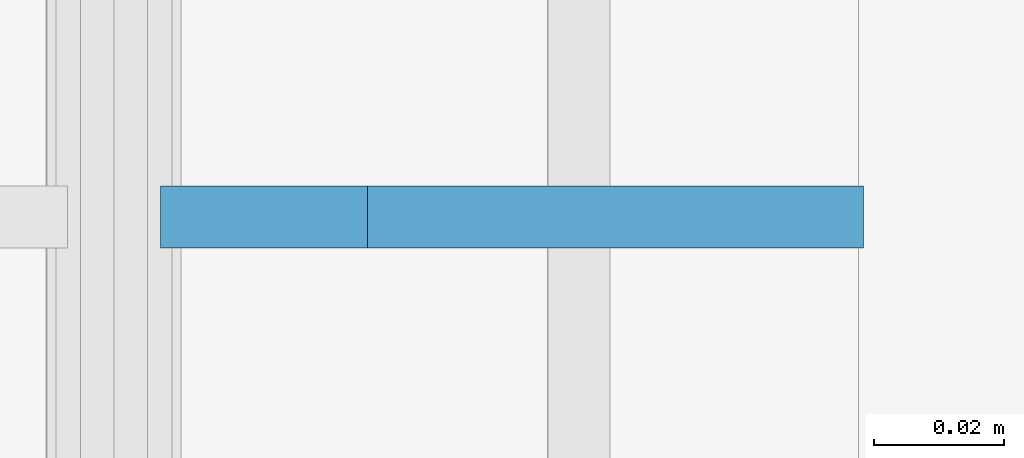
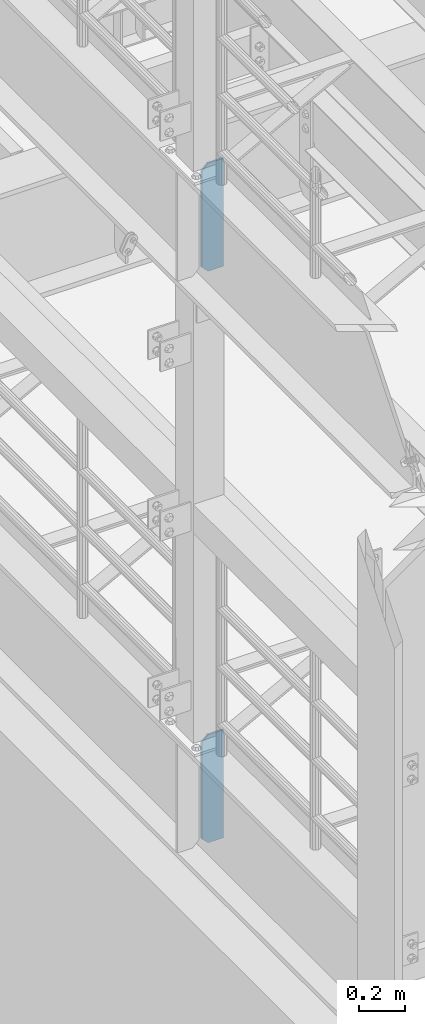
# One storey, part 1483 of 1876: 2 plates, 2 elements without a shape of their own.
"""IFC2X3 building model written with IfcOpenShell, lengths in millimetres."""

from ifc_helpers import new_model, si_unit, frame, origin_with_axes, place, context, subcontext, project, spatial, faceted_brep, material, type_object, element, aggregate, save


model = new_model("IFC2X3")

# Units and contexts
model_context = context("Model", 3, precision=1e-05, world=origin_with_axes())
body_context = subcontext(model_context, "Body", "Model", "MODEL_VIEW")
ifc_project = project(units=[si_unit("LENGTHUNIT", "METRE", prefix="MILLI"), si_unit("AREAUNIT", "SQUARE_METRE"), si_unit("VOLUMEUNIT", "CUBIC_METRE"), si_unit("MASSUNIT", "GRAM", prefix="KILO"), si_unit("TIMEUNIT", "SECOND"), si_unit("PLANEANGLEUNIT", "RADIAN"), si_unit("SOLIDANGLEUNIT", "STERADIAN"), si_unit("THERMODYNAMICTEMPERATUREUNIT", "DEGREE_CELSIUS"), si_unit("LUMINOUSINTENSITYUNIT", "LUMEN")], contexts=[model_context])

# Site, building, storey
site_placement = place(None, origin_with_axes())
site = spatial("IfcSite", under=ifc_project, at=site_placement, CompositionType="ELEMENT")
building_placement = place(site_placement, origin_with_axes())
building = spatial("IfcBuilding", under=site, at=building_placement, Name="Undefined", CompositionType="ELEMENT")
storey_placement = place(building_placement, origin_with_axes())
storey = spatial("IfcBuildingStorey", under=building, at=storey_placement, Name="Undefined", CompositionType="ELEMENT", Elevation=0.0)

# Assembly, plate
assembly_1_placement = place(storey_placement, origin_with_axes())
assembly_1 = element("IfcElementAssembly", 1, at=assembly_1_placement, inside=storey, Name="BEAM", AssemblyPlace="NOTDEFINED", PredefinedType="RIGID_FRAME")
ifc_material = material(Name="STEEL/A36")
plate_type = type_object("IfcPlateType", PredefinedType="NOTDEFINED")
plate_1_placement = place(assembly_1_placement, frame((115.09375, -2540.0, 7556.5), z_axis=(0.0, 0.0, 1.0), x_axis=(-1.0, 0.0, 0.0)))
plate_1 = element("IfcPlate", 2, at=plate_1_placement, type_object=plate_type, material=ifc_material, Name="PLATE", context=body_context, shape_type="Brep", body=[
    faceted_brep([(0.0, -4.76249999999982, 0.0), (0.0, -4.76249999999982, 571.5), (0.0, 4.76249999999982, 571.5), (0.0, 4.76249999999982, 0.0), (76.1999969482422, -4.76249999999982, 571.5), (76.1999969482422, 4.76249999999982, 571.5), (107.949996948242, -4.76249999999982, 539.75), (107.949996948242, 4.76249999999982, 539.75), (107.949996948242, -4.76249999999982, 31.75), (107.949996948242, 4.76249999999982, 31.75), (76.1999969482422, -4.76250000000073, 0.0), (76.1999969482422, 4.76250000000073, 0.0)], [[[0, 1, 2, 3]], [[1, 4, 5, 2]], [[4, 6, 7, 5]], [[6, 8, 9, 7]], [[8, 10, 11, 9]], [[10, 0, 3, 11]], [[5, 7, 9, 11, 3, 2]], [[10, 8, 6, 4, 1, 0]]]),
])
aggregate(assembly_1, [plate_1])

assembly_2_placement = place(storey_placement, origin_with_axes())
assembly_2 = element("IfcElementAssembly", 3, at=assembly_2_placement, inside=storey, Name="BEAM", AssemblyPlace="NOTDEFINED", PredefinedType="RIGID_FRAME")
plate_2_placement = place(assembly_2_placement, frame((115.09375, -2540.0, 4533.9), z_axis=(0.0, 0.0, 1.0), x_axis=(-1.0, 0.0, 0.0)))
plate_2 = element("IfcPlate", 4, at=plate_2_placement, type_object=plate_type, material=ifc_material, Name="PLATE", context=body_context, shape_type="Brep", body=[
    faceted_brep([(0.0, -4.76249999999982, 0.0), (0.0, -4.76249999999982, 571.5), (0.0, 4.76249999999982, 571.5), (0.0, 4.76249999999982, 0.0), (76.1999969482422, -4.76249999999982, 571.5), (76.1999969482422, 4.76249999999982, 571.5), (107.949996948242, -4.76249999999982, 539.75), (107.949996948242, 4.76249999999982, 539.75), (107.949996948242, -4.76249999999982, 31.75), (107.949996948242, 4.76249999999982, 31.75), (76.1999969482422, -4.76250000000073, 0.0), (76.1999969482422, 4.76250000000073, 0.0)], [[[0, 1, 2, 3]], [[1, 4, 5, 2]], [[4, 6, 7, 5]], [[6, 8, 9, 7]], [[8, 10, 11, 9]], [[10, 0, 3, 11]], [[5, 7, 9, 11, 3, 2]], [[10, 8, 6, 4, 1, 0]]]),
])
aggregate(assembly_2, [plate_2])

save(model, "model.ifc")
